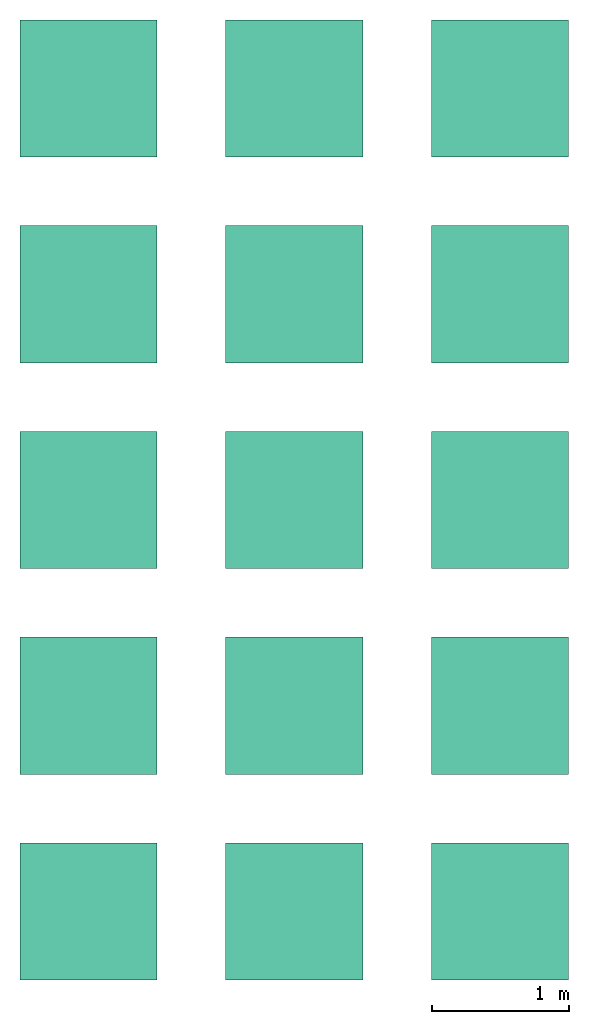
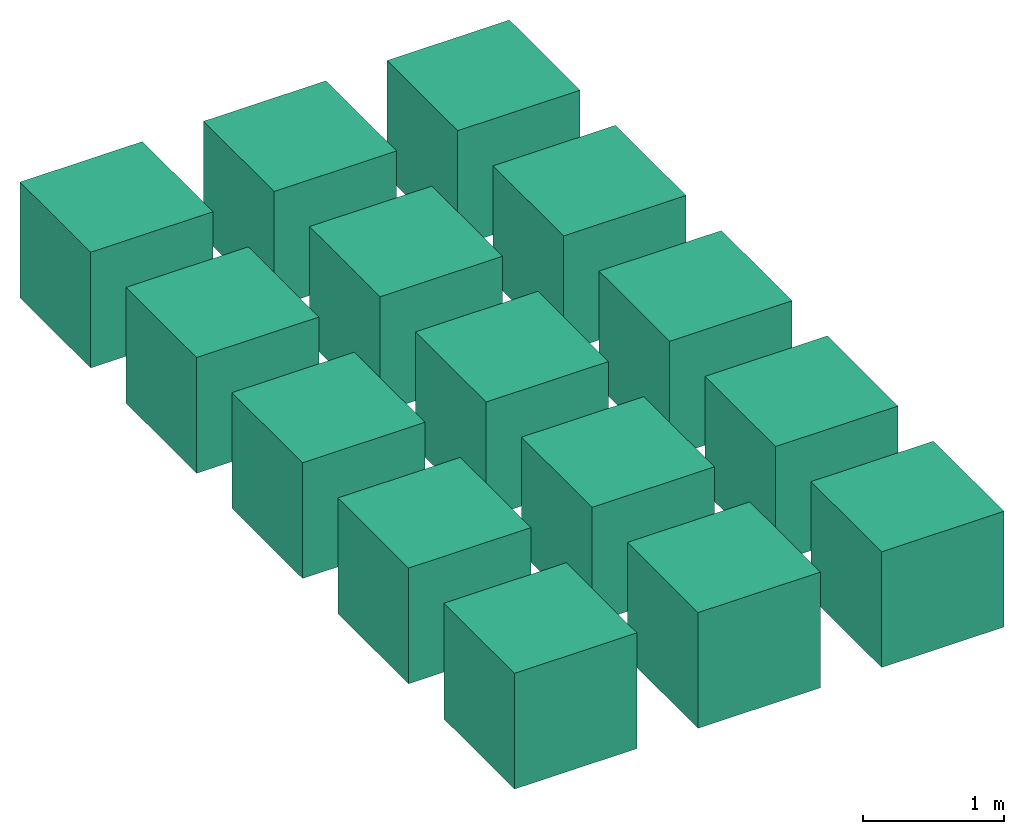
# One storey: 15 actuators.
"""IFC4 building model written with IfcOpenShell, lengths in metres."""

import ifcopenshell
import ifcopenshell.guid

model = None  # the IFC model being written
_history = None  # IfcOwnerHistory: only IFC2X3 demands one
_inside = {}  # id of a spatial element -> (the spatial element, [elements in it])
_under = {}  # id of a project, library or spatial element -> (it, [spatial elements below it])
_declared = {}  # id of a project -> (the project, [libraries it declares])
_typed = {}  # id of a type object -> (the type object, [elements of that type])
_made_of = {}  # id of a material, layer set ... -> (it, [elements and type objects made of it])


def new_model(schema):
    """Start an empty IFC model of exactly this schema.

    Asked for "IFC4X3", IfcOpenShell would pick the latest addendum, in which some entities
    have other attributes; the version numbers below select the first issue.
    IFC2X3 requires an IfcOwnerHistory on every rooted entity: one is made here for all.
    """
    global model, _history
    if schema == "IFC4X3":
        model = ifcopenshell.file(schema_version=(4, 3, 0, 0))
    else:
        model = ifcopenshell.file(schema=schema)
    _inside.clear()
    _under.clear()
    _declared.clear()
    _typed.clear()
    _made_of.clear()
    _history = None
    if model.schema == "IFC2X3":
        org = make("IfcOrganization", Name="unknown")
        user = make(
            "IfcPersonAndOrganization",
            ThePerson=make("IfcPerson", FamilyName="unknown"),
            TheOrganization=org,
        )
        app = make(
            "IfcApplication",
            ApplicationDeveloper=org,
            Version="unknown",
            ApplicationFullName="unknown",
            ApplicationIdentifier="unknown",
        )
        _history = make(
            "IfcOwnerHistory",
            OwningUser=user,
            OwningApplication=app,
            ChangeAction="ADDED",
            CreationDate=0,
        )
    return model


def make(cls, **values):
    """One entity of the class cls with the attributes given. An attribute that is None is left unset."""
    return model.create_entity(
        cls, **{name: value for name, value in values.items() if value is not None}
    )


def rooted(cls, **values):
    """An entity with a GlobalId (a new one), such as an element, a storey or a relation."""
    return make(cls, GlobalId=ifcopenshell.guid.new(), OwnerHistory=_history, **values)


def si_unit(unit_type, name, prefix=None):
    """IfcSIUnit, for example si_unit("LENGTHUNIT", "METRE", prefix="MILLI")."""
    return make("IfcSIUnit", UnitType=unit_type, Prefix=prefix, Name=name)


def assignment(units):
    """IfcUnitAssignment: the units of a project."""
    return None if units is None else make("IfcUnitAssignment", Units=units)


def point(xyz):
    """IfcCartesianPoint."""
    return None if xyz is None else make("IfcCartesianPoint", Coordinates=xyz)


def direction(xyz):
    """IfcDirection."""
    return None if xyz is None else make("IfcDirection", DirectionRatios=xyz)


def frame(location, z_axis=None, x_axis=None):
    """IfcAxis2Placement3D, a coordinate frame: its origin and axes. An axis left out is left unset."""
    return make(
        "IfcAxis2Placement3D",
        Location=point(location),
        Axis=direction(z_axis),
        RefDirection=direction(x_axis),
    )


def origin_with_axes():
    """The frame at (0, 0, 0) with the z axis (0, 0, 1) and the x axis (1, 0, 0) written out."""
    return frame((0.0, 0.0, 0.0), z_axis=(0.0, 0.0, 1.0), x_axis=(1.0, 0.0, 0.0))


def place(relative_to, where):
    """IfcLocalPlacement: puts the frame where relative to a parent placement (None: the world)."""
    return make(
        "IfcLocalPlacement", PlacementRelTo=relative_to, RelativePlacement=where
    )


def context(
    kind, dimensions, precision=None, world=None, true_north=None, identifier=None
):
    """IfcGeometricRepresentationContext, for example the 3D "Model" context."""
    return make(
        "IfcGeometricRepresentationContext",
        ContextIdentifier=identifier,
        ContextType=kind,
        CoordinateSpaceDimension=dimensions,
        Precision=precision,
        WorldCoordinateSystem=world,
        TrueNorth=true_north,
    )


def subcontext(parent, identifier, kind, view, scale=None):
    """IfcGeometricRepresentationSubContext, for example "Body" below "Model"."""
    return make(
        "IfcGeometricRepresentationSubContext",
        ContextIdentifier=identifier,
        ContextType=kind,
        ParentContext=parent,
        TargetScale=scale,
        TargetView=view,
    )


def project(units=None, contexts=None):
    """IfcProject with its units and contexts."""
    return rooted(
        "IfcProject",
        Name="project",
        RepresentationContexts=contexts,
        UnitsInContext=assignment(units),
    )


def spatial(cls, under=None, at=None, **own):
    """A site, building, storey or space (cls), placed at a placement, below another one or the project."""
    s = rooted(cls, ObjectPlacement=at, **own)
    if under is not None:
        _under.setdefault(under.id(), (under, []))[1].append(s)
    return s


def faces_of(points, faces, orient=None, outer=None):
    """IfcFace entities. A face is a list of loops; a loop is a list of indices into points, from 0.

    orient and outer hold one flag for each loop. By default every Orientation is true, the
    first loop of a face is its IfcFaceOuterBound and the others are IfcFaceBound.
    """
    made = []
    for i, loops in enumerate(faces):
        bounds = []
        for j, loop in enumerate(loops):
            is_outer = j == 0 if outer is None else outer[i][j]
            bounds.append(
                make(
                    "IfcFaceOuterBound" if is_outer else "IfcFaceBound",
                    Bound=make("IfcPolyLoop", Polygon=[points[k] for k in loop]),
                    Orientation=True if orient is None else orient[i][j],
                )
            )
        made.append(make("IfcFace", Bounds=bounds))
    return made


def faceted_brep(points, faces, orient=None, outer=None, voids=None):
    """IfcFacetedBrep: a solid bounded by flat faces; with voids (closed shells), ...WithVoids."""
    shared = [point(p) for p in points]
    hull = make("IfcClosedShell", CfsFaces=faces_of(shared, faces, orient, outer))
    if voids is None:
        return make("IfcFacetedBrep", Outer=hull)
    return make(
        "IfcFacetedBrepWithVoids",
        Outer=hull,
        Voids=[
            make(cls, CfsFaces=faces_of(shared, fs, o, b)) for cls, fs, o, b in voids
        ],
    )


def shape(context_of_items, identifier, shape_type, items):
    """IfcShapeRepresentation: the items that make up one representation, for example the "Body"."""
    return make(
        "IfcShapeRepresentation",
        ContextOfItems=context_of_items,
        RepresentationIdentifier=identifier,
        RepresentationType=shape_type,
        Items=items,
    )


def source(mapping_origin, context_of_items, identifier, shape_type, items):
    """IfcRepresentationMap: a shape defined once, which mapped items show again and again."""
    return make(
        "IfcRepresentationMap",
        MappingOrigin=mapping_origin,
        MappedRepresentation=shape(context_of_items, identifier, shape_type, items),
    )


def transform(
    local_origin,
    x_axis=None,
    y_axis=None,
    z_axis=None,
    scale=None,
    scale2=None,
    scale3=None,
    uniform=True,
):
    """IfcCartesianTransformationOperator3D, or its non-uniform kind. x_axis, y_axis, z_axis: its Axis1, 2, 3."""
    if uniform:
        return make(
            "IfcCartesianTransformationOperator3D",
            Axis1=direction(x_axis),
            Axis2=direction(y_axis),
            LocalOrigin=point(local_origin),
            Scale=scale,
            Axis3=direction(z_axis),
        )
    return make(
        "IfcCartesianTransformationOperator3DnonUniform",
        Axis1=direction(x_axis),
        Axis2=direction(y_axis),
        LocalOrigin=point(local_origin),
        Scale=scale,
        Axis3=direction(z_axis),
        Scale2=scale2,
        Scale3=scale3,
    )


def mapped(mapping_source, mapping_target):
    """IfcMappedItem: shows the shape of a source again, moved by a transform."""
    return make(
        "IfcMappedItem", MappingSource=mapping_source, MappingTarget=mapping_target
    )


def material(Name=None, Category=None):
    """IfcMaterial."""
    return make("IfcMaterial", Name=Name, Category=Category)


def made_of(thing, what):
    """Note that an element or type object is made of a material, layer set ...; save() writes the relation."""
    if what is not None:
        _made_of.setdefault(what.id(), (what, []))[1].append(thing)
    return thing


def element(
    cls,
    number,
    at=None,
    inside=None,
    cuts=None,
    type_object=None,
    material=None,
    context=None,
    identifier="Body",
    shape_type=None,
    held_by="IfcProductDefinitionShape",
    body=None,
    shapes=None,
    **own,
):
    """One element of the class cls, such as IfcWall. Its Tag is "e" and its number.

    at: its placement. inside: the storey or other place that contains it. cuts: it is an
    opening in that element (IfcRelVoidsElement). A single representation is given by context,
    identifier, shape_type and body (its items); several are given by shapes. held_by: the class
    of the entity that holds the representations. save() writes the other relations.
    """
    e = rooted(cls, Tag="e%d" % number, ObjectPlacement=at, **own)
    if body is not None:
        shapes = [shape(context, identifier, shape_type, body)]
    if shapes is not None:
        e.Representation = make(held_by, Representations=shapes)
    if inside is not None:
        _inside.setdefault(inside.id(), (inside, []))[1].append(e)
    if cuts is not None:
        rooted(
            "IfcRelVoidsElement", RelatingBuildingElement=cuts, RelatedOpeningElement=e
        )
    if type_object is not None:
        _typed.setdefault(type_object.id(), (type_object, []))[1].append(e)
    return made_of(e, material)


def aggregate(whole, parts):
    """IfcRelAggregates: a whole, such as a stair, and the parts it consists of."""
    return rooted("IfcRelAggregates", RelatingObject=whole, RelatedObjects=parts)


def save(model, path):
    """Write the relations noted so far, then the file.

    IfcRelAggregates (storeys below a building ...), IfcRelContainedInSpatialStructure (elements
    in a storey), IfcRelDefinesByType, IfcRelAssociatesMaterial and IfcRelDeclares: one each for
    every whole, place, type object, material and project.
    """
    for whole, parts in _under.values():
        aggregate(whole, parts)
    for where, things in _inside.values():
        rooted(
            "IfcRelContainedInSpatialStructure",
            RelatedElements=things,
            RelatingStructure=where,
        )
    for kind, things in _typed.values():
        rooted("IfcRelDefinesByType", RelatedObjects=things, RelatingType=kind)
    for what, things in _made_of.values():
        rooted("IfcRelAssociatesMaterial", RelatedObjects=things, RelatingMaterial=what)
    for by, libraries in _declared.values():
        rooted("IfcRelDeclares", RelatingContext=by, RelatedDefinitions=libraries)
    model.write(path)


model = new_model("IFC4")

# Units and contexts
model_context = context("Model", 3, precision=1e-05, world=origin_with_axes())
plan_context = context("Plan", 2, precision=1e-05, world=origin_with_axes())
body_context = subcontext(model_context, "Body", "Model", "MODEL_VIEW")
ifc_project = project(units=[si_unit("LENGTHUNIT", "METRE"), si_unit("AREAUNIT", "SQUARE_METRE"), si_unit("VOLUMEUNIT", "CUBIC_METRE")], contexts=[model_context, plan_context])

# Site, building, storey
site_placement = place(None, origin_with_axes())
site = spatial("IfcSite", under=ifc_project, at=site_placement)
building_placement = place(site_placement, origin_with_axes())
building = spatial("IfcBuilding", under=site, at=building_placement, Name="Building")
storey_placement = place(building_placement, origin_with_axes())
storey = spatial("IfcBuildingStorey", under=building, at=storey_placement, Name="Ground Floor")

# Actuators
ifc_material_1 = material(Name="diagonal3")
shared_shape_1 = source(origin_with_axes(), body_context, "Body", "Brep", [
    faceted_brep([(2.50000023841858, 0.5, -0.5), (3.50000023841858, 0.5, -0.5), (3.50000023841858, -0.5, -0.5), (2.50000023841858, -0.5, -0.5), (2.50000023841858, -0.5, 0.5), (2.50000023841858, 0.5, 0.5), (3.50000023841858, -0.5, 0.5), (3.50000023841858, 0.5, 0.5)], [[[0, 1, 2, 3]], [[3, 4, 5, 0]], [[2, 6, 4, 3]], [[1, 7, 6, 2]], [[7, 5, 4, 6]], [[0, 5, 7, 1]]]),
])
actuator_1_placement = place(None, origin_with_axes())
element("IfcActuator", 1, at=actuator_1_placement, inside=storey, material=ifc_material_1, Name="Cube.002", PredefinedType="ELECTRICACTUATOR", context=body_context, shape_type="MappedRepresentation", body=[
    mapped(shared_shape_1, transform((0.0, 0.0, 0.0), x_axis=(1.0, 0.0, 0.0), y_axis=(0.0, 1.0, 0.0), z_axis=(0.0, 0.0, 1.0), scale=1.0)),
])
ifc_material_2 = material(Name="brick")
shared_shape_2 = source(origin_with_axes(), body_context, "Body", "Brep", [
    faceted_brep([(-0.5, -2.49999976158142, -0.5), (0.5, -2.49999976158142, -0.5), (0.5, -3.49999976158142, -0.5), (-0.5, -3.49999976158142, -0.5), (-0.5, -3.49999976158142, 0.5), (-0.5, -2.49999976158142, 0.5), (0.5, -3.49999976158142, 0.5), (0.5, -2.49999976158142, 0.5)], [[[0, 1, 2, 3]], [[3, 4, 5, 0]], [[2, 6, 4, 3]], [[1, 7, 6, 2]], [[7, 5, 4, 6]], [[0, 5, 7, 1]]]),
])
actuator_2_placement = place(None, origin_with_axes())
element("IfcActuator", 2, at=actuator_2_placement, inside=storey, material=ifc_material_2, Name="Cube.006", PredefinedType="ELECTRICACTUATOR", context=body_context, shape_type="MappedRepresentation", body=[
    mapped(shared_shape_2, transform((0.0, 0.0, 0.0), x_axis=(1.0, 0.0, 0.0), y_axis=(0.0, 1.0, 0.0), z_axis=(0.0, 0.0, 1.0), scale=1.0)),
])
ifc_material_3 = material(Name="grass")
shared_shape_3 = source(origin_with_axes(), body_context, "Body", "Brep", [
    faceted_brep([(1.00000011920929, -3.99999952316284, -0.5), (2.0, -3.99999952316284, -0.5), (2.0, -4.99999952316284, -0.5), (1.00000011920929, -4.99999952316284, -0.5), (1.00000011920929, -4.99999952316284, 0.5), (1.00000011920929, -3.99999952316284, 0.5), (2.0, -4.99999952316284, 0.5), (2.0, -3.99999952316284, 0.5)], [[[0, 1, 2, 3]], [[3, 4, 5, 0]], [[2, 6, 4, 3]], [[1, 7, 6, 2]], [[7, 5, 4, 6]], [[0, 5, 7, 1]]]),
])
actuator_3_placement = place(None, origin_with_axes())
element("IfcActuator", 3, at=actuator_3_placement, inside=storey, material=ifc_material_3, Name="Cube.010", PredefinedType="ELECTRICACTUATOR", context=body_context, shape_type="MappedRepresentation", body=[
    mapped(shared_shape_3, transform((0.0, 0.0, 0.0), x_axis=(1.0, 0.0, 0.0), y_axis=(0.0, 1.0, 0.0), z_axis=(0.0, 0.0, 1.0), scale=1.0)),
])
shared_shape_4 = source(origin_with_axes(), body_context, "Body", "Brep", [
    faceted_brep([(2.50000023841858, -5.49999952316284, -0.5), (3.50000023841858, -5.49999952316284, -0.5), (3.50000023841858, -6.49999952316284, -0.5), (2.50000023841858, -6.49999952316284, -0.5), (2.50000023841858, -6.49999952316284, 0.5), (2.50000023841858, -5.49999952316284, 0.5), (3.50000023841858, -6.49999952316284, 0.5), (3.50000023841858, -5.49999952316284, 0.5)], [[[0, 1, 2, 3]], [[3, 4, 5, 0]], [[2, 6, 4, 3]], [[1, 7, 6, 2]], [[7, 5, 4, 6]], [[0, 5, 7, 1]]]),
])
actuator_4_placement = place(None, origin_with_axes())
element("IfcActuator", 4, at=actuator_4_placement, inside=storey, Name="Cube.014", PredefinedType="ELECTRICACTUATOR", context=body_context, shape_type="MappedRepresentation", body=[
    mapped(shared_shape_4, transform((0.0, 0.0, 0.0), x_axis=(1.0, 0.0, 0.0), y_axis=(0.0, 1.0, 0.0), z_axis=(0.0, 0.0, 1.0), scale=1.0)),
])
ifc_material_4 = material(Name="diagonal2")
shared_shape_5 = source(origin_with_axes(), body_context, "Body", "Brep", [
    faceted_brep([(1.00000011920929, 0.5, -0.5), (2.0, 0.5, -0.5), (2.0, -0.5, -0.5), (1.00000011920929, -0.5, -0.5), (1.00000011920929, -0.5, 0.5), (1.00000011920929, 0.5, 0.5), (2.0, -0.5, 0.5), (2.0, 0.5, 0.5)], [[[0, 1, 2, 3]], [[3, 4, 5, 0]], [[2, 6, 4, 3]], [[1, 7, 6, 2]], [[7, 5, 4, 6]], [[0, 5, 7, 1]]]),
])
actuator_5_placement = place(None, origin_with_axes())
element("IfcActuator", 5, at=actuator_5_placement, inside=storey, material=ifc_material_4, Name="Cube.001", PredefinedType="ELECTRICACTUATOR", context=body_context, shape_type="MappedRepresentation", body=[
    mapped(shared_shape_5, transform((0.0, 0.0, 0.0), x_axis=(1.0, 0.0, 0.0), y_axis=(0.0, 1.0, 0.0), z_axis=(0.0, 0.0, 1.0), scale=1.0)),
])
ifc_material_5 = material(Name="crosshatch3")
shared_shape_6 = source(origin_with_axes(), body_context, "Body", "Brep", [
    faceted_brep([(2.50000023841858, -0.99999988079071, -0.5), (3.50000023841858, -0.99999988079071, -0.5), (3.50000023841858, -1.99999988079071, -0.5), (2.50000023841858, -1.99999988079071, -0.5), (2.50000023841858, -1.99999988079071, 0.5), (2.50000023841858, -0.99999988079071, 0.5), (3.50000023841858, -1.99999988079071, 0.5), (3.50000023841858, -0.99999988079071, 0.5)], [[[0, 1, 2, 3]], [[3, 4, 5, 0]], [[2, 6, 4, 3]], [[1, 7, 6, 2]], [[7, 5, 4, 6]], [[0, 5, 7, 1]]]),
])
actuator_6_placement = place(None, origin_with_axes())
element("IfcActuator", 6, at=actuator_6_placement, inside=storey, material=ifc_material_5, Name="Cube.005", PredefinedType="ELECTRICACTUATOR", context=body_context, shape_type="MappedRepresentation", body=[
    mapped(shared_shape_6, transform((0.0, 0.0, 0.0), x_axis=(1.0, 0.0, 0.0), y_axis=(0.0, 1.0, 0.0), z_axis=(0.0, 0.0, 1.0), scale=1.0)),
])
ifc_material_6 = material(Name="liquid")
shared_shape_7 = source(origin_with_axes(), body_context, "Body", "Brep", [
    faceted_brep([(-0.5, -3.99999952316284, -0.5), (0.5, -3.99999952316284, -0.5), (0.5, -4.99999952316284, -0.5), (-0.5, -4.99999952316284, -0.5), (-0.5, -4.99999952316284, 0.5), (-0.5, -3.99999952316284, 0.5), (0.5, -4.99999952316284, 0.5), (0.5, -3.99999952316284, 0.5)], [[[0, 1, 2, 3]], [[3, 4, 5, 0]], [[2, 6, 4, 3]], [[1, 7, 6, 2]], [[7, 5, 4, 6]], [[0, 5, 7, 1]]]),
])
actuator_7_placement = place(None, origin_with_axes())
element("IfcActuator", 7, at=actuator_7_placement, inside=storey, material=ifc_material_6, Name="Cube.009", PredefinedType="ELECTRICACTUATOR", context=body_context, shape_type="MappedRepresentation", body=[
    mapped(shared_shape_7, transform((0.0, 0.0, 0.0), x_axis=(1.0, 0.0, 0.0), y_axis=(0.0, 1.0, 0.0), z_axis=(0.0, 0.0, 1.0), scale=1.0)),
])
ifc_material_7 = material(Name="concrete")
shared_shape_8 = source(origin_with_axes(), body_context, "Body", "Brep", [
    faceted_brep([(1.00000011920929, -5.49999952316284, -0.5), (2.0, -5.49999952316284, -0.5), (2.0, -6.49999952316284, -0.5), (1.00000011920929, -6.49999952316284, -0.5), (1.00000011920929, -6.49999952316284, 0.5), (1.00000011920929, -5.49999952316284, 0.5), (2.0, -6.49999952316284, 0.5), (2.0, -5.49999952316284, 0.5)], [[[0, 1, 2, 3]], [[3, 4, 5, 0]], [[2, 6, 4, 3]], [[1, 7, 6, 2]], [[7, 5, 4, 6]], [[0, 5, 7, 1]]]),
])
actuator_8_placement = place(None, origin_with_axes())
element("IfcActuator", 8, at=actuator_8_placement, inside=storey, material=ifc_material_7, Name="Cube.013", PredefinedType="ELECTRICACTUATOR", context=body_context, shape_type="MappedRepresentation", body=[
    mapped(shared_shape_8, transform((0.0, 0.0, 0.0), x_axis=(1.0, 0.0, 0.0), y_axis=(0.0, 1.0, 0.0), z_axis=(0.0, 0.0, 1.0), scale=1.0)),
])
ifc_material_8 = material(Name="diagonal1")
shared_shape_9 = source(origin_with_axes(), body_context, "Body", "Brep", [
    faceted_brep([(-0.5, -0.5, -0.5), (-0.5, -0.5, 0.5), (-0.5, 0.5, 0.5), (-0.5, 0.5, -0.5), (0.5, 0.5, 0.5), (0.5, 0.5, -0.5), (0.5, -0.5, 0.5), (0.5, -0.5, -0.5)], [[[0, 1, 2, 3]], [[3, 2, 4, 5]], [[5, 4, 6, 7]], [[7, 6, 1, 0]], [[3, 5, 7, 0]], [[4, 2, 1, 6]]]),
])
actuator_9_placement = place(None, origin_with_axes())
element("IfcActuator", 9, at=actuator_9_placement, inside=storey, material=ifc_material_8, Name="Cube", PredefinedType="ELECTRICACTUATOR", context=body_context, shape_type="MappedRepresentation", body=[
    mapped(shared_shape_9, transform((0.0, 0.0, 0.0), x_axis=(1.0, 0.0, 0.0), y_axis=(0.0, 1.0, 0.0), z_axis=(0.0, 0.0, 1.0), scale=1.0)),
])
ifc_material_9 = material(Name="crosshatch2")
shared_shape_10 = source(origin_with_axes(), body_context, "Body", "Brep", [
    faceted_brep([(1.00000011920929, -0.99999988079071, -0.5), (2.0, -0.99999988079071, -0.5), (2.0, -1.99999988079071, -0.5), (1.00000011920929, -1.99999988079071, -0.5), (1.00000011920929, -1.99999988079071, 0.5), (1.00000011920929, -0.99999988079071, 0.5), (2.0, -1.99999988079071, 0.5), (2.0, -0.99999988079071, 0.5)], [[[0, 1, 2, 3]], [[3, 4, 5, 0]], [[2, 6, 4, 3]], [[1, 7, 6, 2]], [[7, 5, 4, 6]], [[0, 5, 7, 1]]]),
])
actuator_10_placement = place(None, origin_with_axes())
element("IfcActuator", 10, at=actuator_10_placement, inside=storey, material=ifc_material_9, Name="Cube.004", PredefinedType="ELECTRICACTUATOR", context=body_context, shape_type="MappedRepresentation", body=[
    mapped(shared_shape_10, transform((0.0, 0.0, 0.0), x_axis=(1.0, 0.0, 0.0), y_axis=(0.0, 1.0, 0.0), z_axis=(0.0, 0.0, 1.0), scale=1.0)),
])
ifc_material_10 = material(Name="glass")
shared_shape_11 = source(origin_with_axes(), body_context, "Body", "Brep", [
    faceted_brep([(2.50000023841858, -2.49999976158142, -0.5), (3.50000023841858, -2.49999976158142, -0.5), (3.50000023841858, -3.49999976158142, -0.5), (2.50000023841858, -3.49999976158142, -0.5), (2.50000023841858, -3.49999976158142, 0.5), (2.50000023841858, -2.49999976158142, 0.5), (3.50000023841858, -3.49999976158142, 0.5), (3.50000023841858, -2.49999976158142, 0.5)], [[[0, 1, 2, 3]], [[3, 4, 5, 0]], [[2, 6, 4, 3]], [[1, 7, 6, 2]], [[7, 5, 4, 6]], [[0, 5, 7, 1]]]),
])
actuator_11_placement = place(None, origin_with_axes())
element("IfcActuator", 11, at=actuator_11_placement, inside=storey, material=ifc_material_10, Name="Cube.008", PredefinedType="ELECTRICACTUATOR", context=body_context, shape_type="MappedRepresentation", body=[
    mapped(shared_shape_11, transform((0.0, 0.0, 0.0), x_axis=(1.0, 0.0, 0.0), y_axis=(0.0, 1.0, 0.0), z_axis=(0.0, 0.0, 1.0), scale=1.0)),
])
ifc_material_11 = material(Name="sand")
shared_shape_12 = source(origin_with_axes(), body_context, "Body", "Brep", [
    faceted_brep([(-0.5, -5.49999952316284, -0.5), (0.5, -5.49999952316284, -0.5), (0.5, -6.49999952316284, -0.5), (-0.5, -6.49999952316284, -0.5), (-0.5, -6.49999952316284, 0.5), (-0.5, -5.49999952316284, 0.5), (0.5, -6.49999952316284, 0.5), (0.5, -5.49999952316284, 0.5)], [[[0, 1, 2, 3]], [[3, 4, 5, 0]], [[2, 6, 4, 3]], [[1, 7, 6, 2]], [[7, 5, 4, 6]], [[0, 5, 7, 1]]]),
])
actuator_12_placement = place(None, origin_with_axes())
element("IfcActuator", 12, at=actuator_12_placement, inside=storey, material=ifc_material_11, Name="Cube.012", PredefinedType="ELECTRICACTUATOR", context=body_context, shape_type="MappedRepresentation", body=[
    mapped(shared_shape_12, transform((0.0, 0.0, 0.0), x_axis=(1.0, 0.0, 0.0), y_axis=(0.0, 1.0, 0.0), z_axis=(0.0, 0.0, 1.0), scale=1.0)),
])
ifc_material_12 = material(Name="crosshatch1")
shared_shape_13 = source(origin_with_axes(), body_context, "Body", "Brep", [
    faceted_brep([(-0.5, -0.99999988079071, -0.5), (0.5, -0.99999988079071, -0.5), (0.5, -1.99999988079071, -0.5), (-0.5, -1.99999988079071, -0.5), (-0.5, -1.99999988079071, 0.5), (-0.5, -0.99999988079071, 0.5), (0.5, -1.99999988079071, 0.5), (0.5, -0.99999988079071, 0.5)], [[[0, 1, 2, 3]], [[3, 4, 5, 0]], [[2, 6, 4, 3]], [[1, 7, 6, 2]], [[7, 5, 4, 6]], [[0, 5, 7, 1]]]),
])
actuator_13_placement = place(None, origin_with_axes())
element("IfcActuator", 13, at=actuator_13_placement, inside=storey, material=ifc_material_12, Name="Cube.003", PredefinedType="ELECTRICACTUATOR", context=body_context, shape_type="MappedRepresentation", body=[
    mapped(shared_shape_13, transform((0.0, 0.0, 0.0), x_axis=(1.0, 0.0, 0.0), y_axis=(0.0, 1.0, 0.0), z_axis=(0.0, 0.0, 1.0), scale=1.0)),
])
ifc_material_13 = material(Name="earth")
shared_shape_14 = source(origin_with_axes(), body_context, "Body", "Brep", [
    faceted_brep([(1.00000011920929, -2.49999976158142, -0.5), (2.0, -2.49999976158142, -0.5), (2.0, -3.49999976158142, -0.5), (1.00000011920929, -3.49999976158142, -0.5), (1.00000011920929, -3.49999976158142, 0.5), (1.00000011920929, -2.49999976158142, 0.5), (2.0, -3.49999976158142, 0.5), (2.0, -2.49999976158142, 0.5)], [[[0, 1, 2, 3]], [[3, 4, 5, 0]], [[2, 6, 4, 3]], [[1, 7, 6, 2]], [[7, 5, 4, 6]], [[0, 5, 7, 1]]]),
])
actuator_14_placement = place(None, origin_with_axes())
element("IfcActuator", 14, at=actuator_14_placement, inside=storey, material=ifc_material_13, Name="Cube.007", PredefinedType="ELECTRICACTUATOR", context=body_context, shape_type="MappedRepresentation", body=[
    mapped(shared_shape_14, transform((0.0, 0.0, 0.0), x_axis=(1.0, 0.0, 0.0), y_axis=(0.0, 1.0, 0.0), z_axis=(0.0, 0.0, 1.0), scale=1.0)),
])
ifc_material_14 = material(Name="honeycomb")
shared_shape_15 = source(origin_with_axes(), body_context, "Body", "Brep", [
    faceted_brep([(2.50000023841858, -3.99999952316284, -0.5), (3.50000023841858, -3.99999952316284, -0.5), (3.50000023841858, -4.99999952316284, -0.5), (2.50000023841858, -4.99999952316284, -0.5), (2.50000023841858, -4.99999952316284, 0.5), (2.50000023841858, -3.99999952316284, 0.5), (3.50000023841858, -4.99999952316284, 0.5), (3.50000023841858, -3.99999952316284, 0.5)], [[[0, 1, 2, 3]], [[3, 4, 5, 0]], [[2, 6, 4, 3]], [[1, 7, 6, 2]], [[7, 5, 4, 6]], [[0, 5, 7, 1]]]),
])
actuator_15_placement = place(None, origin_with_axes())
element("IfcActuator", 15, at=actuator_15_placement, inside=storey, material=ifc_material_14, Name="Cube.011", PredefinedType="ELECTRICACTUATOR", context=body_context, shape_type="MappedRepresentation", body=[
    mapped(shared_shape_15, transform((0.0, 0.0, 0.0), x_axis=(1.0, 0.0, 0.0), y_axis=(0.0, 1.0, 0.0), z_axis=(0.0, 0.0, 1.0), scale=1.0)),
])

save(model, "model.ifc")
